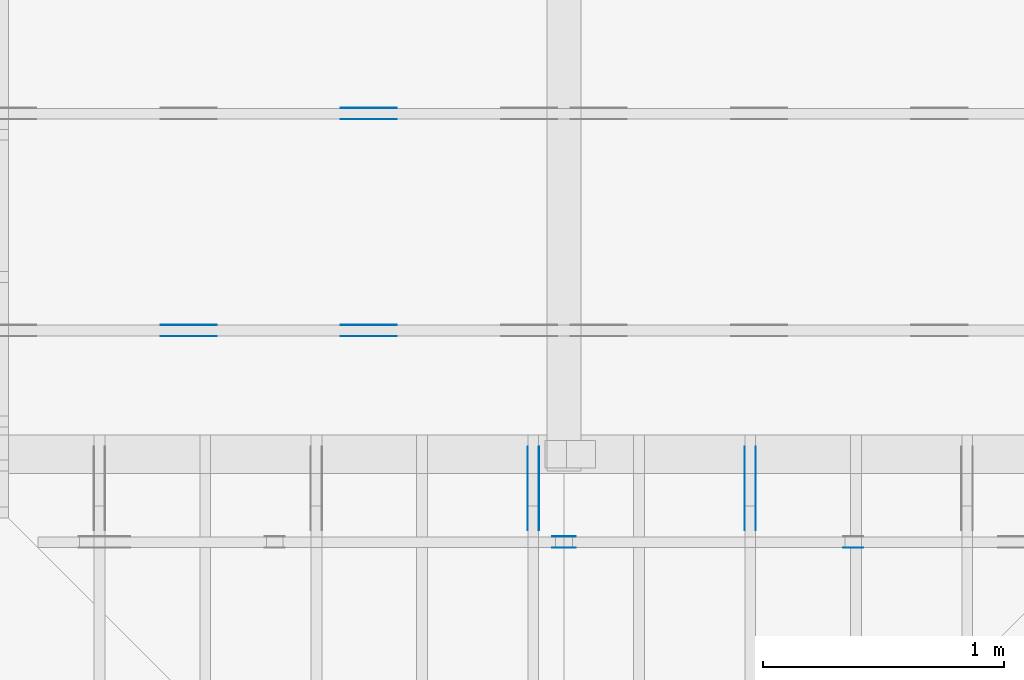
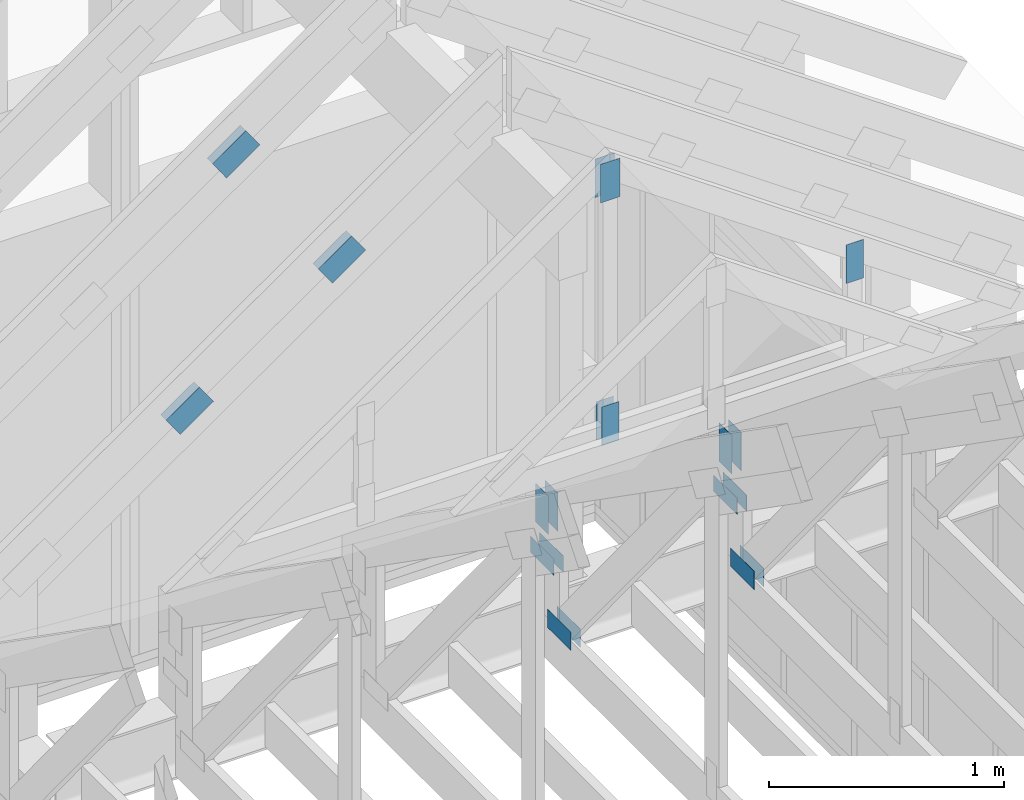
# One storey, part 62 of 70: 23 plates, 5 elements without a shape of their own.
"""IFC2X3 building model written with IfcOpenShell, lengths in millimetres."""

from ifc_helpers import new_model, si_unit, frame, origin, origin_with_axes, origin_2d, place, context, project, spatial, faceted_brep, element, aggregate, save


model = new_model("IFC2X3")

# Units and contexts
model_context = context("Model", 3, precision=1e-05, world=origin())
plan_context = context("Plan", 2, precision=1e-05, world=origin_2d())
ifc_project = project(units=[si_unit("LENGTHUNIT", "METRE", prefix="MILLI"), si_unit("AREAUNIT", "SQUARE_METRE"), si_unit("VOLUMEUNIT", "CUBIC_METRE"), si_unit("SOLIDANGLEUNIT", "STERADIAN"), si_unit("PLANEANGLEUNIT", "RADIAN"), si_unit("MASSUNIT", "GRAM"), si_unit("TIMEUNIT", "SECOND"), si_unit("THERMODYNAMICTEMPERATUREUNIT", "DEGREE_CELSIUS"), si_unit("LUMINOUSINTENSITYUNIT", "LUMEN")], contexts=[model_context, plan_context])

# Site, building, storey
site_placement = place(None, origin_with_axes())
site = spatial("IfcSite", under=ifc_project, at=site_placement, CompositionType="ELEMENT")
building_placement = place(site_placement, origin_with_axes())
building = spatial("IfcBuilding", under=site, at=building_placement, Name="Layout 1", CompositionType="ELEMENT")
storey_placement = place(building_placement, origin_with_axes())
storey = spatial("IfcBuildingStorey", under=building, at=storey_placement, Name="Storey 1", CompositionType="ELEMENT", Elevation=0.0)

# Assembly, plates
assembly_1_placement = place(storey_placement, frame((7000.0, 9505.0, 1.3776821480501744e-15), z_axis=(1.2246063538223773e-16, 1.0, 6.123031769111886e-17), x_axis=(-1.0, 1.2246063538223773e-16, 0.0)))
assembly_1 = element("IfcElementAssembly", 1, at=assembly_1_placement, inside=storey, Name="T4", AssemblyPlace="FACTORY", PredefinedType="TRUSS")
plate_1_placement = place(assembly_1_placement, frame((-1806.2295569137375, 1953.4380313546214, 0.0), z_axis=(0.0, 0.0, 1.0), x_axis=(0.819152044288992, -0.5735764363510462, 0.0)))
plate_1 = element("IfcPlate", 2, at=plate_1_placement, context=model_context, shape_type="Brep", body=[
    faceted_brep([(200.00000000000045, 120.00000000000023, 1.3), (0.0, 120.00000000000023, 1.3), (4.547473508864641e-13, 1.1368683772161603e-13, 1.3), (200.00000000000045, 1.1368683772161603e-13, 1.3), (0.0, 120.00000000000023, 0.0), (200.00000000000045, 120.00000000000023, 2.4492127076447602e-14), (200.00000000000045, 0.0, 2.4492127076447602e-14), (4.547473508864641e-13, 0.0, 5.56886495279458e-29), (200.00000000000045, -1.0068703683308056e-13, 6.165099252666911e-30), (200.00000000000045, -1.006074374200821e-13, 1.3), (4.547473508864641e-13, 1.1376643713461424e-13, 1.3), (4.547473508864641e-13, 1.1368683772161579e-13, 1.401298464324817e-44), (200.00000000000045, 120.0, 0.0), (200.00000000000045, 120.0, 1.3), (200.00000000000045, 0.0, 1.3), (200.00000000000045, 0.0, 0.0), (0.0, 120.00000000000023, 0.0), (0.0, 120.00000000000023, 1.3), (200.00000000000045, 120.0, 1.3), (200.00000000000045, 120.0, 0.0), (4.547473508864642e-13, 1.1368683772161603e-13, -1.1210387714598537e-44), (4.548269502994627e-13, 1.1368683772161603e-13, 1.3), (4.3196585089270716e-14, 120.00000000000023, 1.3), (4.311698567627228e-14, 120.00000000000023, -2.6400667308415748e-30)], [[[0, 1, 2, 3]], [[4, 5, 6, 7]], [[8, 9, 10, 11]], [[12, 13, 14, 15]], [[16, 17, 18, 19]], [[20, 21, 22, 23]]]),
])
plate_2_placement = place(assembly_1_placement, frame((-1806.2295569137375, 1953.4380313546214, -46.300000000000004), z_axis=(0.0, 0.0, 1.0), x_axis=(0.819152044288992, -0.5735764363510462, 0.0)))
plate_2 = element("IfcPlate", 3, at=plate_2_placement, context=model_context, shape_type="Brep", body=[
    faceted_brep([(200.00000000000045, 120.00000000000023, 1.2999999999999972), (0.0, 120.00000000000023, 1.2999999999999972), (4.547473508864641e-13, 1.1368683772161603e-13, 1.2999999999999972), (200.00000000000045, 1.1368683772161603e-13, 1.2999999999999972), (0.0, 120.00000000000023, 0.0), (200.00000000000045, 120.00000000000023, 2.4492127076447602e-14), (200.00000000000045, 0.0, 2.4492127076447602e-14), (4.547473508864641e-13, 0.0, 5.56886495279458e-29), (200.00000000000045, -1.0068703683308056e-13, 6.165099252666911e-30), (200.00000000000045, -1.006074374200821e-13, 1.2999999999999972), (4.547473508864641e-13, 1.1376643713461424e-13, 1.2999999999999972), (4.547473508864641e-13, 1.1368683772161579e-13, 1.401298464324817e-44), (200.00000000000045, 120.0, 0.0), (200.00000000000045, 120.0, 1.2999999999999972), (200.00000000000045, 0.0, 1.2999999999999972), (200.00000000000045, 0.0, 0.0), (0.0, 120.00000000000023, 0.0), (0.0, 120.00000000000023, 1.2999999999999972), (200.00000000000045, 120.0, 1.2999999999999972), (200.00000000000045, 120.0, 0.0), (4.547473508864642e-13, 1.1368683772161603e-13, -1.1210387714598537e-44), (4.548269502994627e-13, 1.1368683772161603e-13, 1.2999999999999972), (4.3196585089270716e-14, 120.00000000000023, 1.2999999999999972), (4.311698567627228e-14, 120.00000000000023, -2.6400667308415748e-30)], [[[0, 1, 2, 3]], [[4, 5, 6, 7]], [[8, 9, 10, 11]], [[12, 13, 14, 15]], [[16, 17, 18, 19]], [[20, 21, 22, 23]]]),
])
aggregate(assembly_1, [plate_1, plate_2])

assembly_2_placement = place(storey_placement, frame((7000.0, 8605.0, 1.3776821480501744e-15), z_axis=(1.2246063538223773e-16, 1.0, 6.123031769111886e-17), x_axis=(-1.0, 1.2246063538223773e-16, 0.0)))
assembly_2 = element("IfcElementAssembly", 4, at=assembly_2_placement, inside=storey, Name="T4", AssemblyPlace="FACTORY", PredefinedType="TRUSS")
plate_3_placement = place(assembly_2_placement, frame((-1058.7796737620245, 1430.0679887373412, 0.0), z_axis=(0.0, 0.0, 1.0), x_axis=(0.819152044288992, -0.5735764363510462, 0.0)))
plate_3 = element("IfcPlate", 5, at=plate_3_placement, context=model_context, shape_type="Brep", body=[
    faceted_brep([(200.00000000000023, 120.0, 1.3), (0.0, 120.0, 1.3), (2.2737367544323206e-13, 0.0, 1.3), (200.0, 0.0, 1.3), (0.0, 120.0, 0.0), (200.00000000000023, 120.0, 2.4492127076447574e-14), (200.0, 0.0, 2.4492127076447545e-14), (2.2737367544323206e-13, 0.0, 2.78443247639729e-29), (200.0, -3.673819061467132e-14, 2.249491082733206e-30), (200.0, -3.6658591201672864e-14, 1.3), (2.2737367544323206e-13, 7.959941299841276e-17, 1.3), (2.2737367544323206e-13, -4.176648714595935e-29, 2.5573752767891235e-45), (200.0, 120.0, -1.4199496293978212e-29), (200.0, 120.0, 1.3), (200.0, 0.0, 1.3), (200.0, 0.0, 0.0), (0.0, 120.0, 0.0), (-4.8738973459219465e-33, 120.0, 1.3), (200.00000000000023, 119.99999999999999, 1.3), (200.00000000000023, 119.99999999999999, 0.0), (2.2737367544323206e-13, 0.0, 0.0), (2.274532748562305e-13, 1.669984074232364e-31, 1.3), (-2.430497480793855e-14, 120.0, 1.3), (-2.4384574220936983e-14, 120.0, 1.4930752263106387e-30)], [[[0, 1, 2, 3]], [[4, 5, 6, 7]], [[8, 9, 10, 11]], [[12, 13, 14, 15]], [[16, 17, 18, 19]], [[20, 21, 22, 23]]]),
])
plate_4_placement = place(assembly_2_placement, frame((-1058.7796737620245, 1430.0679887373412, -46.300000000000004), z_axis=(0.0, 0.0, 1.0), x_axis=(0.819152044288992, -0.5735764363510462, 0.0)))
plate_4 = element("IfcPlate", 6, at=plate_4_placement, context=model_context, shape_type="Brep", body=[
    faceted_brep([(200.00000000000023, 120.0, 1.2999999999999972), (0.0, 120.0, 1.2999999999999972), (2.2737367544323206e-13, 0.0, 1.2999999999999972), (200.0, 0.0, 1.2999999999999972), (0.0, 120.0, 0.0), (200.00000000000023, 120.0, 2.4492127076447574e-14), (200.0, 0.0, 2.4492127076447545e-14), (2.2737367544323206e-13, 0.0, 2.78443247639729e-29), (200.0, -3.673819061467132e-14, 2.249491082733206e-30), (200.0, -3.6658591201672864e-14, 1.2999999999999972), (2.2737367544323206e-13, 7.959941299841258e-17, 1.2999999999999972), (2.2737367544323206e-13, -4.176648714595935e-29, 2.5573752767891235e-45), (200.0, 120.0, -1.4199496293978212e-29), (200.0, 120.0, 1.2999999999999972), (200.0, 0.0, 1.2999999999999972), (200.0, 0.0, 0.0), (0.0, 120.0, 0.0), (-4.873897345921936e-33, 120.0, 1.2999999999999972), (200.00000000000023, 119.99999999999999, 1.2999999999999972), (200.00000000000023, 119.99999999999999, 0.0), (2.2737367544323206e-13, 0.0, 0.0), (2.274532748562305e-13, 1.669984074232364e-31, 1.2999999999999972), (-2.430497480793855e-14, 120.0, 1.2999999999999972), (-2.4384574220936983e-14, 120.0, 1.4930752263106387e-30)], [[[0, 1, 2, 3]], [[4, 5, 6, 7]], [[8, 9, 10, 11]], [[12, 13, 14, 15]], [[16, 17, 18, 19]], [[20, 21, 22, 23]]]),
])
plate_5_placement = place(assembly_2_placement, frame((-1806.2295569137375, 1953.4380313546214, 0.0), z_axis=(0.0, 0.0, 1.0), x_axis=(0.819152044288992, -0.5735764363510462, 0.0)))
plate_5 = element("IfcPlate", 7, at=plate_5_placement, context=model_context, shape_type="Brep", body=[
    faceted_brep([(200.00000000000045, 120.00000000000023, 1.3), (0.0, 120.00000000000023, 1.3), (4.547473508864641e-13, 1.1368683772161603e-13, 1.3), (200.00000000000045, 1.1368683772161603e-13, 1.3), (0.0, 120.00000000000023, 0.0), (200.00000000000045, 120.00000000000023, 2.4492127076447602e-14), (200.00000000000045, 0.0, 2.4492127076447602e-14), (4.547473508864641e-13, 0.0, 5.56886495279458e-29), (200.00000000000045, -1.0068703683308056e-13, 6.165099252666911e-30), (200.00000000000045, -1.006074374200821e-13, 1.3), (4.547473508864641e-13, 1.1376643713461424e-13, 1.3), (4.547473508864641e-13, 1.1368683772161579e-13, 1.401298464324817e-44), (200.00000000000045, 120.0, 0.0), (200.00000000000045, 120.0, 1.3), (200.00000000000045, 0.0, 1.3), (200.00000000000045, 0.0, 0.0), (0.0, 120.00000000000023, 0.0), (0.0, 120.00000000000023, 1.3), (200.00000000000045, 120.0, 1.3), (200.00000000000045, 120.0, 0.0), (4.547473508864642e-13, 1.1368683772161603e-13, -1.1210387714598537e-44), (4.548269502994627e-13, 1.1368683772161603e-13, 1.3), (4.3196585089270716e-14, 120.00000000000023, 1.3), (4.311698567627228e-14, 120.00000000000023, -2.6400667308415748e-30)], [[[0, 1, 2, 3]], [[4, 5, 6, 7]], [[8, 9, 10, 11]], [[12, 13, 14, 15]], [[16, 17, 18, 19]], [[20, 21, 22, 23]]]),
])
plate_6_placement = place(assembly_2_placement, frame((-1806.2295569137375, 1953.4380313546214, -46.300000000000004), z_axis=(0.0, 0.0, 1.0), x_axis=(0.819152044288992, -0.5735764363510462, 0.0)))
plate_6 = element("IfcPlate", 8, at=plate_6_placement, context=model_context, shape_type="Brep", body=[
    faceted_brep([(200.00000000000045, 120.00000000000023, 1.2999999999999972), (0.0, 120.00000000000023, 1.2999999999999972), (4.547473508864641e-13, 1.1368683772161603e-13, 1.2999999999999972), (200.00000000000045, 1.1368683772161603e-13, 1.2999999999999972), (0.0, 120.00000000000023, 0.0), (200.00000000000045, 120.00000000000023, 2.4492127076447602e-14), (200.00000000000045, 0.0, 2.4492127076447602e-14), (4.547473508864641e-13, 0.0, 5.56886495279458e-29), (200.00000000000045, -1.0068703683308056e-13, 6.165099252666911e-30), (200.00000000000045, -1.006074374200821e-13, 1.2999999999999972), (4.547473508864641e-13, 1.1376643713461424e-13, 1.2999999999999972), (4.547473508864641e-13, 1.1368683772161579e-13, 1.401298464324817e-44), (200.00000000000045, 120.0, 0.0), (200.00000000000045, 120.0, 1.2999999999999972), (200.00000000000045, 0.0, 1.2999999999999972), (200.00000000000045, 0.0, 0.0), (0.0, 120.00000000000023, 0.0), (0.0, 120.00000000000023, 1.2999999999999972), (200.00000000000045, 120.0, 1.2999999999999972), (200.00000000000045, 120.0, 0.0), (4.547473508864642e-13, 1.1368683772161603e-13, -1.1210387714598537e-44), (4.548269502994627e-13, 1.1368683772161603e-13, 1.2999999999999972), (4.3196585089270716e-14, 120.00000000000023, 1.2999999999999972), (4.311698567627228e-14, 120.00000000000023, -2.6400667308415748e-30)], [[[0, 1, 2, 3]], [[4, 5, 6, 7]], [[8, 9, 10, 11]], [[12, 13, 14, 15]], [[16, 17, 18, 19]], [[20, 21, 22, 23]]]),
])
aggregate(assembly_2, [plate_3, plate_4, plate_5, plate_6])

assembly_3_placement = place(storey_placement, frame((10250.0, 8000.0, -9.081170196248781e-13), z_axis=(-1.0, 1.836909530733566e-16, 6.123031769111886e-17), x_axis=(-1.836909530733566e-16, -1.0, 0.0)))
assembly_3 = element("IfcElementAssembly", 9, at=assembly_3_placement, inside=storey, Name="T3", AssemblyPlace="FACTORY", PredefinedType="TRUSS")
plate_7_placement = place(assembly_3_placement, frame((100.0, 559.2244775947038, 0.0), z_axis=(0.0, 0.0, 1.0), x_axis=(-1.0, 1.2246063538223773e-16, 0.0)))
plate_7 = element("IfcPlate", 10, at=plate_7_placement, context=model_context, shape_type="Brep", body=[
    faceted_brep([(200.0, 84.0, 1.3), (0.0, 84.0, 1.3), (0.0, 0.0, 1.3), (200.0, 0.0, 1.3), (0.0, 84.0, 0.0), (200.0, 84.0, 2.4492127076447545e-14), (200.0, 0.0, 2.4492127076447545e-14), (0.0, 0.0, 0.0), (200.0, -3.673819061467132e-14, 2.249491082733206e-30), (200.0, -3.6658591201672864e-14, 1.3), (1.4621692037765842e-32, 7.959941299845453e-17, 1.3), (0.0, 0.0, 0.0), (200.0, 84.0, 0.0), (200.0, 84.0, 1.3), (200.0, 0.0, 1.3), (200.0, 0.0, 0.0), (0.0, 84.0, 0.0), (-4.8738973459219465e-33, 84.0, 1.3), (200.0, 83.99999999999999, 1.3), (200.0, 83.99999999999999, -7.888609052210118e-31), (0.0, 0.0, 0.0), (7.959941299845453e-17, -9.747794691843893e-33, 1.3), (1.0366292785106424e-14, 84.0, 1.3), (1.0286693372107969e-14, 84.0, -6.298575031652977e-31)], [[[0, 1, 2, 3]], [[4, 5, 6, 7]], [[8, 9, 10, 11]], [[12, 13, 14, 15]], [[16, 17, 18, 19]], [[20, 21, 22, 23]]]),
])
plate_8_placement = place(assembly_3_placement, frame((100.0, 559.2244775947038, -46.3), z_axis=(0.0, 0.0, 1.0), x_axis=(-1.0, 1.2246063538223773e-16, 0.0)))
plate_8 = element("IfcPlate", 11, at=plate_8_placement, context=model_context, shape_type="Brep", body=[
    faceted_brep([(200.0, 84.0, 1.2999999999999972), (0.0, 84.0, 1.2999999999999972), (0.0, 0.0, 1.2999999999999972), (200.0, 0.0, 1.2999999999999972), (0.0, 84.0, 0.0), (200.0, 84.0, 2.4492127076447545e-14), (200.0, 0.0, 2.4492127076447545e-14), (0.0, 0.0, 0.0), (200.0, -3.673819061467132e-14, 2.249491082733206e-30), (200.0, -3.6658591201672864e-14, 1.2999999999999972), (1.462169203776581e-32, 7.959941299845434e-17, 1.2999999999999972), (0.0, 0.0, 0.0), (200.0, 84.0, 0.0), (200.0, 84.0, 1.2999999999999972), (200.0, 0.0, 1.2999999999999972), (200.0, 0.0, 0.0), (0.0, 84.0, 0.0), (-4.873897345921936e-33, 84.0, 1.2999999999999972), (200.0, 83.99999999999999, 1.2999999999999972), (200.0, 83.99999999999999, -7.888609052210118e-31), (0.0, 0.0, 0.0), (7.959941299845434e-17, -9.747794691843873e-33, 1.2999999999999972), (1.0366292785106424e-14, 84.0, 1.2999999999999972), (1.0286693372107969e-14, 84.0, -6.298575031652977e-31)], [[[0, 1, 2, 3]], [[4, 5, 6, 7]], [[8, 9, 10, 11]], [[12, 13, 14, 15]], [[16, 17, 18, 19]], [[20, 21, 22, 23]]]),
])
plate_9_placement = place(assembly_3_placement, frame((54.00000000004449, 658.8550844100489, 0.0), z_axis=(0.0, 0.0, 1.0), x_axis=(6.123031769111886e-17, 1.0, 0.0)))
plate_9 = element("IfcPlate", 12, at=plate_9_placement, context=model_context, shape_type="Brep", body=[
    faceted_brep([(200.0, 108.0, 1.3), (0.0, 108.0, 1.3), (0.0, 7.105427357601002e-15, 1.3), (200.0, 7.105427357601002e-15, 1.3), (0.0, 108.0, 0.0), (200.0, 108.0, 2.4492127076447545e-14), (200.0, 0.0, 2.4492127076447545e-14), (0.0, 0.0, 0.0), (200.0, -2.9632763257070316e-14, 1.8144235082961296e-30), (200.0, -2.955316384407186e-14, 1.3), (1.4621692037765823e-32, 7.185026770599457e-15, 1.3), (0.0, 7.105427357601002e-15, 0.0), (200.0, 108.0, 0.0), (200.0, 108.0, 1.3), (200.0, 0.0, 1.3), (200.0, 0.0, 0.0), (0.0, 108.0, 0.0), (-4.8738973459219465e-33, 108.0, 1.3), (200.0, 107.99999999999999, 1.3), (200.0, 107.99999999999999, -7.888609052210118e-31), (8.701351488741532e-31, 7.105427357601002e-15, -5.327865159977341e-47), (7.95994129984554e-17, 7.105427357601002e-15, 1.3), (1.330534803428013e-14, 108.0, 1.3), (1.3225748621281674e-14, 108.0, -8.098167897839542e-31)], [[[0, 1, 2, 3]], [[4, 5, 6, 7]], [[8, 9, 10, 11]], [[12, 13, 14, 15]], [[16, 17, 18, 19]], [[20, 21, 22, 23]]]),
])
plate_10_placement = place(assembly_3_placement, frame((54.00000000004449, 658.8550844100489, -46.3), z_axis=(0.0, 0.0, 1.0), x_axis=(6.123031769111886e-17, 1.0, 0.0)))
plate_10 = element("IfcPlate", 13, at=plate_10_placement, context=model_context, shape_type="Brep", body=[
    faceted_brep([(200.0, 108.0, 1.2999999999999972), (0.0, 108.0, 1.2999999999999972), (0.0, 7.105427357601002e-15, 1.2999999999999972), (200.0, 7.105427357601002e-15, 1.2999999999999972), (0.0, 108.0, 0.0), (200.0, 108.0, 2.4492127076447545e-14), (200.0, 0.0, 2.4492127076447545e-14), (0.0, 0.0, 0.0), (200.0, -2.9632763257070316e-14, 1.8144235082961296e-30), (200.0, -2.955316384407186e-14, 1.2999999999999972), (1.4621692037765823e-32, 7.185026770599457e-15, 1.2999999999999972), (0.0, 7.105427357601002e-15, 0.0), (200.0, 108.0, 0.0), (200.0, 108.0, 1.2999999999999972), (200.0, 0.0, 1.2999999999999972), (200.0, 0.0, 0.0), (0.0, 108.0, 0.0), (-4.873897345921936e-33, 108.0, 1.2999999999999972), (200.0, 107.99999999999999, 1.2999999999999972), (200.0, 107.99999999999999, -7.888609052210118e-31), (8.701351488741532e-31, 7.105427357601002e-15, -5.327865159977341e-47), (7.959941299845522e-17, 7.105427357601002e-15, 1.2999999999999972), (1.330534803428013e-14, 108.0, 1.2999999999999972), (1.3225748621281674e-14, 108.0, -8.098167897839542e-31)], [[[0, 1, 2, 3]], [[4, 5, 6, 7]], [[8, 9, 10, 11]], [[12, 13, 14, 15]], [[16, 17, 18, 19]], [[20, 21, 22, 23]]]),
])
plate_11_placement = place(assembly_3_placement, frame((44.999999998137355, 172.00000000000097, 0.0), z_axis=(0.0, 0.0, 1.0), x_axis=(1.0, 0.0, 0.0)))
plate_11 = element("IfcPlate", 14, at=plate_11_placement, context=model_context, shape_type="Brep", body=[
    faceted_brep([(200.0, 96.0, 1.3), (0.0, 96.0, 1.3), (0.0, 0.0, 1.3), (200.0, 0.0, 1.3), (0.0, 96.0, 0.0), (200.0, 96.0, 2.4492127076447545e-14), (200.0, 0.0, 2.4492127076447545e-14), (0.0, 0.0, 0.0), (200.0, -3.673819061467132e-14, 2.249491082733206e-30), (200.0, -3.6658591201672864e-14, 1.3), (1.4621692037765842e-32, 7.959941299845453e-17, 1.3), (0.0, 0.0, 0.0), (200.0, 96.0, 0.0), (200.0, 96.0, 1.3), (200.0, 0.0, 1.3), (200.0, 0.0, 0.0), (0.0, 96.0, 0.0), (-4.8738973459219465e-33, 96.0, 1.3), (200.0, 95.99999999999999, 1.3), (200.0, 95.99999999999999, -7.888609052210118e-31), (0.0, 0.0, 0.0), (7.959941299845453e-17, -9.747794691843893e-33, 1.3), (1.1835820409693277e-14, 96.0, 1.3), (1.1756220996694822e-14, 96.0, -7.19837146474626e-31)], [[[0, 1, 2, 3]], [[4, 5, 6, 7]], [[8, 9, 10, 11]], [[12, 13, 14, 15]], [[16, 17, 18, 19]], [[20, 21, 22, 23]]]),
])
plate_12_placement = place(assembly_3_placement, frame((44.999999998137355, 172.00000000000097, -46.3), z_axis=(0.0, 0.0, 1.0), x_axis=(1.0, 0.0, 0.0)))
plate_12 = element("IfcPlate", 15, at=plate_12_placement, context=model_context, shape_type="Brep", body=[
    faceted_brep([(200.0, 96.0, 1.2999999999999972), (0.0, 96.0, 1.2999999999999972), (0.0, 0.0, 1.2999999999999972), (200.0, 0.0, 1.2999999999999972), (0.0, 96.0, 0.0), (200.0, 96.0, 2.4492127076447545e-14), (200.0, 0.0, 2.4492127076447545e-14), (0.0, 0.0, 0.0), (200.0, -3.673819061467132e-14, 2.249491082733206e-30), (200.0, -3.6658591201672864e-14, 1.2999999999999972), (1.462169203776581e-32, 7.959941299845434e-17, 1.2999999999999972), (0.0, 0.0, 0.0), (200.0, 96.0, 0.0), (200.0, 96.0, 1.2999999999999972), (200.0, 0.0, 1.2999999999999972), (200.0, 0.0, 0.0), (0.0, 96.0, 0.0), (-4.873897345921936e-33, 96.0, 1.2999999999999972), (200.0, 95.99999999999999, 1.2999999999999972), (200.0, 95.99999999999999, -7.888609052210118e-31), (0.0, 0.0, 0.0), (7.959941299845434e-17, -9.747794691843873e-33, 1.2999999999999972), (1.1835820409693277e-14, 96.0, 1.2999999999999972), (1.1756220996694822e-14, 96.0, -7.19837146474626e-31)], [[[0, 1, 2, 3]], [[4, 5, 6, 7]], [[8, 9, 10, 11]], [[12, 13, 14, 15]], [[16, 17, 18, 19]], [[20, 21, 22, 23]]]),
])
aggregate(assembly_3, [plate_7, plate_8, plate_9, plate_10, plate_11, plate_12])

assembly_4_placement = place(storey_placement, frame((9350.0, 8000.0, -9.081170196248781e-13), z_axis=(-1.0, 1.836909530733566e-16, 6.123031769111886e-17), x_axis=(-1.836909530733566e-16, -1.0, 0.0)))
assembly_4 = element("IfcElementAssembly", 16, at=assembly_4_placement, inside=storey, Name="T3", AssemblyPlace="FACTORY", PredefinedType="TRUSS")
plate_13_placement = place(assembly_4_placement, frame((100.0, 559.2244775947038, 0.0), z_axis=(0.0, 0.0, 1.0), x_axis=(-1.0, 1.2246063538223773e-16, 0.0)))
plate_13 = element("IfcPlate", 17, at=plate_13_placement, context=model_context, shape_type="Brep", body=[
    faceted_brep([(200.0, 84.0, 1.3), (0.0, 84.0, 1.3), (0.0, 0.0, 1.3), (200.0, 0.0, 1.3), (0.0, 84.0, 0.0), (200.0, 84.0, 2.4492127076447545e-14), (200.0, 0.0, 2.4492127076447545e-14), (0.0, 0.0, 0.0), (200.0, -3.673819061467132e-14, 2.249491082733206e-30), (200.0, -3.6658591201672864e-14, 1.3), (1.4621692037765842e-32, 7.959941299845453e-17, 1.3), (0.0, 0.0, 0.0), (200.0, 84.0, 0.0), (200.0, 84.0, 1.3), (200.0, 0.0, 1.3), (200.0, 0.0, 0.0), (0.0, 84.0, 0.0), (-4.8738973459219465e-33, 84.0, 1.3), (200.0, 83.99999999999999, 1.3), (200.0, 83.99999999999999, -7.888609052210118e-31), (0.0, 0.0, 0.0), (7.959941299845453e-17, -9.747794691843893e-33, 1.3), (1.0366292785106424e-14, 84.0, 1.3), (1.0286693372107969e-14, 84.0, -6.298575031652977e-31)], [[[0, 1, 2, 3]], [[4, 5, 6, 7]], [[8, 9, 10, 11]], [[12, 13, 14, 15]], [[16, 17, 18, 19]], [[20, 21, 22, 23]]]),
])
plate_14_placement = place(assembly_4_placement, frame((100.0, 559.2244775947038, -46.3), z_axis=(0.0, 0.0, 1.0), x_axis=(-1.0, 1.2246063538223773e-16, 0.0)))
plate_14 = element("IfcPlate", 18, at=plate_14_placement, context=model_context, shape_type="Brep", body=[
    faceted_brep([(200.0, 84.0, 1.2999999999999972), (0.0, 84.0, 1.2999999999999972), (0.0, 0.0, 1.2999999999999972), (200.0, 0.0, 1.2999999999999972), (0.0, 84.0, 0.0), (200.0, 84.0, 2.4492127076447545e-14), (200.0, 0.0, 2.4492127076447545e-14), (0.0, 0.0, 0.0), (200.0, -3.673819061467132e-14, 2.249491082733206e-30), (200.0, -3.6658591201672864e-14, 1.2999999999999972), (1.462169203776581e-32, 7.959941299845434e-17, 1.2999999999999972), (0.0, 0.0, 0.0), (200.0, 84.0, 0.0), (200.0, 84.0, 1.2999999999999972), (200.0, 0.0, 1.2999999999999972), (200.0, 0.0, 0.0), (0.0, 84.0, 0.0), (-4.873897345921936e-33, 84.0, 1.2999999999999972), (200.0, 83.99999999999999, 1.2999999999999972), (200.0, 83.99999999999999, -7.888609052210118e-31), (0.0, 0.0, 0.0), (7.959941299845434e-17, -9.747794691843873e-33, 1.2999999999999972), (1.0366292785106424e-14, 84.0, 1.2999999999999972), (1.0286693372107969e-14, 84.0, -6.298575031652977e-31)], [[[0, 1, 2, 3]], [[4, 5, 6, 7]], [[8, 9, 10, 11]], [[12, 13, 14, 15]], [[16, 17, 18, 19]], [[20, 21, 22, 23]]]),
])
plate_15_placement = place(assembly_4_placement, frame((54.00000000004449, 658.8550844100489, 0.0), z_axis=(0.0, 0.0, 1.0), x_axis=(6.123031769111886e-17, 1.0, 0.0)))
plate_15 = element("IfcPlate", 19, at=plate_15_placement, context=model_context, shape_type="Brep", body=[
    faceted_brep([(200.0, 108.0, 1.3), (0.0, 108.0, 1.3), (0.0, 7.105427357601002e-15, 1.3), (200.0, 7.105427357601002e-15, 1.3), (0.0, 108.0, 0.0), (200.0, 108.0, 2.4492127076447545e-14), (200.0, 0.0, 2.4492127076447545e-14), (0.0, 0.0, 0.0), (200.0, -2.9632763257070316e-14, 1.8144235082961296e-30), (200.0, -2.955316384407186e-14, 1.3), (1.4621692037765823e-32, 7.185026770599457e-15, 1.3), (0.0, 7.105427357601002e-15, 0.0), (200.0, 108.0, 0.0), (200.0, 108.0, 1.3), (200.0, 0.0, 1.3), (200.0, 0.0, 0.0), (0.0, 108.0, 0.0), (-4.8738973459219465e-33, 108.0, 1.3), (200.0, 107.99999999999999, 1.3), (200.0, 107.99999999999999, -7.888609052210118e-31), (8.701351488741532e-31, 7.105427357601002e-15, -5.327865159977341e-47), (7.95994129984554e-17, 7.105427357601002e-15, 1.3), (1.330534803428013e-14, 108.0, 1.3), (1.3225748621281674e-14, 108.0, -8.098167897839542e-31)], [[[0, 1, 2, 3]], [[4, 5, 6, 7]], [[8, 9, 10, 11]], [[12, 13, 14, 15]], [[16, 17, 18, 19]], [[20, 21, 22, 23]]]),
])
plate_16_placement = place(assembly_4_placement, frame((54.00000000004449, 658.8550844100489, -46.3), z_axis=(0.0, 0.0, 1.0), x_axis=(6.123031769111886e-17, 1.0, 0.0)))
plate_16 = element("IfcPlate", 20, at=plate_16_placement, context=model_context, shape_type="Brep", body=[
    faceted_brep([(200.0, 108.0, 1.2999999999999972), (0.0, 108.0, 1.2999999999999972), (0.0, 7.105427357601002e-15, 1.2999999999999972), (200.0, 7.105427357601002e-15, 1.2999999999999972), (0.0, 108.0, 0.0), (200.0, 108.0, 2.4492127076447545e-14), (200.0, 0.0, 2.4492127076447545e-14), (0.0, 0.0, 0.0), (200.0, -2.9632763257070316e-14, 1.8144235082961296e-30), (200.0, -2.955316384407186e-14, 1.2999999999999972), (1.4621692037765823e-32, 7.185026770599457e-15, 1.2999999999999972), (0.0, 7.105427357601002e-15, 0.0), (200.0, 108.0, 0.0), (200.0, 108.0, 1.2999999999999972), (200.0, 0.0, 1.2999999999999972), (200.0, 0.0, 0.0), (0.0, 108.0, 0.0), (-4.873897345921936e-33, 108.0, 1.2999999999999972), (200.0, 107.99999999999999, 1.2999999999999972), (200.0, 107.99999999999999, -7.888609052210118e-31), (8.701351488741532e-31, 7.105427357601002e-15, -5.327865159977341e-47), (7.959941299845522e-17, 7.105427357601002e-15, 1.2999999999999972), (1.330534803428013e-14, 108.0, 1.2999999999999972), (1.3225748621281674e-14, 108.0, -8.098167897839542e-31)], [[[0, 1, 2, 3]], [[4, 5, 6, 7]], [[8, 9, 10, 11]], [[12, 13, 14, 15]], [[16, 17, 18, 19]], [[20, 21, 22, 23]]]),
])
plate_17_placement = place(assembly_4_placement, frame((44.999999998137355, 172.00000000000097, 0.0), z_axis=(0.0, 0.0, 1.0), x_axis=(1.0, 0.0, 0.0)))
plate_17 = element("IfcPlate", 21, at=plate_17_placement, context=model_context, shape_type="Brep", body=[
    faceted_brep([(200.0, 96.0, 1.3), (0.0, 96.0, 1.3), (0.0, 0.0, 1.3), (200.0, 0.0, 1.3), (0.0, 96.0, 0.0), (200.0, 96.0, 2.4492127076447545e-14), (200.0, 0.0, 2.4492127076447545e-14), (0.0, 0.0, 0.0), (200.0, -3.673819061467132e-14, 2.249491082733206e-30), (200.0, -3.6658591201672864e-14, 1.3), (1.4621692037765842e-32, 7.959941299845453e-17, 1.3), (0.0, 0.0, 0.0), (200.0, 96.0, 0.0), (200.0, 96.0, 1.3), (200.0, 0.0, 1.3), (200.0, 0.0, 0.0), (0.0, 96.0, 0.0), (-4.8738973459219465e-33, 96.0, 1.3), (200.0, 95.99999999999999, 1.3), (200.0, 95.99999999999999, -7.888609052210118e-31), (0.0, 0.0, 0.0), (7.959941299845453e-17, -9.747794691843893e-33, 1.3), (1.1835820409693277e-14, 96.0, 1.3), (1.1756220996694822e-14, 96.0, -7.19837146474626e-31)], [[[0, 1, 2, 3]], [[4, 5, 6, 7]], [[8, 9, 10, 11]], [[12, 13, 14, 15]], [[16, 17, 18, 19]], [[20, 21, 22, 23]]]),
])
plate_18_placement = place(assembly_4_placement, frame((44.999999998137355, 172.00000000000097, -46.3), z_axis=(0.0, 0.0, 1.0), x_axis=(1.0, 0.0, 0.0)))
plate_18 = element("IfcPlate", 22, at=plate_18_placement, context=model_context, shape_type="Brep", body=[
    faceted_brep([(200.0, 96.0, 1.2999999999999972), (0.0, 96.0, 1.2999999999999972), (0.0, 0.0, 1.2999999999999972), (200.0, 0.0, 1.2999999999999972), (0.0, 96.0, 0.0), (200.0, 96.0, 2.4492127076447545e-14), (200.0, 0.0, 2.4492127076447545e-14), (0.0, 0.0, 0.0), (200.0, -3.673819061467132e-14, 2.249491082733206e-30), (200.0, -3.6658591201672864e-14, 1.2999999999999972), (1.462169203776581e-32, 7.959941299845434e-17, 1.2999999999999972), (0.0, 0.0, 0.0), (200.0, 96.0, 0.0), (200.0, 96.0, 1.2999999999999972), (200.0, 0.0, 1.2999999999999972), (200.0, 0.0, 0.0), (0.0, 96.0, 0.0), (-4.873897345921936e-33, 96.0, 1.2999999999999972), (200.0, 95.99999999999999, 1.2999999999999972), (200.0, 95.99999999999999, -7.888609052210118e-31), (0.0, 0.0, 0.0), (7.959941299845434e-17, -9.747794691843873e-33, 1.2999999999999972), (1.1835820409693277e-14, 96.0, 1.2999999999999972), (1.1756220996694822e-14, 96.0, -7.19837146474626e-31)], [[[0, 1, 2, 3]], [[4, 5, 6, 7]], [[8, 9, 10, 11]], [[12, 13, 14, 15]], [[16, 17, 18, 19]], [[20, 21, 22, 23]]]),
])
aggregate(assembly_4, [plate_13, plate_14, plate_15, plate_16, plate_17, plate_18])

assembly_5_placement = place(storey_placement, frame((7294.999999999998, 7682.5, 1206.561223771864), z_axis=(0.0, -1.0, 6.123031769111886e-17), x_axis=(1.0, 0.0, 0.0)))
assembly_5 = element("IfcElementAssembly", 23, at=assembly_5_placement, inside=storey, Name="SB1", AssemblyPlace="FACTORY", PredefinedType="TRUSS")
plate_19_placement = place(assembly_5_placement, frame((2157.0, 1497.4646711014211, 0.0), z_axis=(0.0, 0.0, 1.0), x_axis=(6.123031769111886e-17, -1.0, 0.0)))
plate_19 = element("IfcPlate", 24, at=plate_19_placement, context=model_context, shape_type="Brep", body=[
    faceted_brep([(200.0, 96.0, 1.3), (0.0, 96.0, 1.3), (0.0, 0.0, 1.3), (200.0, 0.0, 1.3), (0.0, 96.0, 0.0), (200.0, 96.0, 2.4492127076447545e-14), (200.0, 0.0, 2.4492127076447545e-14), (0.0, 0.0, 0.0), (200.0, -3.673819061467132e-14, 2.249491082733206e-30), (200.0, -3.6658591201672864e-14, 1.3), (1.4621692037765842e-32, 7.959941299845453e-17, 1.3), (0.0, 0.0, 0.0), (200.0, 96.0, 0.0), (200.0, 96.0, 1.3), (200.0, 0.0, 1.3), (200.0, 0.0, 0.0), (0.0, 96.0, 0.0), (-4.8738973459219465e-33, 96.0, 1.3), (200.0, 95.99999999999999, 1.3), (200.0, 95.99999999999999, -7.888609052210118e-31), (0.0, 0.0, 0.0), (7.959941299845453e-17, -9.747794691843893e-33, 1.3), (1.1835820409693277e-14, 96.0, 1.3), (1.1756220996694822e-14, 96.0, -7.19837146474626e-31)], [[[0, 1, 2, 3]], [[4, 5, 6, 7]], [[8, 9, 10, 11]], [[12, 13, 14, 15]], [[16, 17, 18, 19]], [[20, 21, 22, 23]]]),
])
plate_20_placement = place(assembly_5_placement, frame((2157.0, 1497.4646711014211, -46.3), z_axis=(0.0, 0.0, 1.0), x_axis=(6.123031769111886e-17, -1.0, 0.0)))
plate_20 = element("IfcPlate", 25, at=plate_20_placement, context=model_context, shape_type="Brep", body=[
    faceted_brep([(200.0, 96.0, 1.2999999999999972), (0.0, 96.0, 1.2999999999999972), (0.0, 0.0, 1.2999999999999972), (200.0, 0.0, 1.2999999999999972), (0.0, 96.0, 0.0), (200.0, 96.0, 2.4492127076447545e-14), (200.0, 0.0, 2.4492127076447545e-14), (0.0, 0.0, 0.0), (200.0, -3.673819061467132e-14, 2.249491082733206e-30), (200.0, -3.6658591201672864e-14, 1.2999999999999972), (1.462169203776581e-32, 7.959941299845434e-17, 1.2999999999999972), (0.0, 0.0, 0.0), (200.0, 96.0, 0.0), (200.0, 96.0, 1.2999999999999972), (200.0, 0.0, 1.2999999999999972), (200.0, 0.0, 0.0), (0.0, 96.0, 0.0), (-4.873897345921936e-33, 96.0, 1.2999999999999972), (200.0, 95.99999999999999, 1.2999999999999972), (200.0, 95.99999999999999, -7.888609052210118e-31), (0.0, 0.0, 0.0), (7.959941299845434e-17, -9.747794691843873e-33, 1.2999999999999972), (1.1835820409693277e-14, 96.0, 1.2999999999999972), (1.1756220996694822e-14, 96.0, -7.19837146474626e-31)], [[[0, 1, 2, 3]], [[4, 5, 6, 7]], [[8, 9, 10, 11]], [[12, 13, 14, 15]], [[16, 17, 18, 19]], [[20, 21, 22, 23]]]),
])
plate_21_placement = place(assembly_5_placement, frame((3362.999999999998, 657.2156252501233, 0.0), z_axis=(0.0, 0.0, 1.0), x_axis=(-1.0489927069340377e-15, -1.0, 0.0)))
plate_21 = element("IfcPlate", 26, at=plate_21_placement, context=model_context, shape_type="Brep", body=[
    faceted_brep([(200.0, 84.0, 1.3), (0.0, 84.0, 1.3), (0.0, 0.0, 1.3), (200.0, 0.0, 1.3), (0.0, 84.0, 0.0), (200.0, 84.0, 2.4492127076447545e-14), (200.0, 4.547473508864641e-13, 2.4492127076447545e-14), (0.0, 4.547473508864641e-13, 0.0), (200.0, 3.185331772653788e-13, 8.340437124852278e-30), (200.0, 3.186127766783772e-13, 1.3), (-1.2677526965428406e-31, 7.959941299845453e-17, 1.3), (0.0, 0.0, 0.0), (200.0, 84.00000000000045, 0.0), (200.0, 84.00000000000045, 1.3), (200.0, 4.547473508864641e-13, 1.3), (200.0, 4.547473508864641e-13, 0.0), (0.0, 84.0, 0.0), (0.0, 84.0, 1.3), (200.0, 84.00000000000048, 1.3), (200.0, 84.00000000000048, 1.5777218104420236e-30), (0.0, 0.0, 0.0), (7.959941299845453e-17, -9.747794691843893e-33, 1.3), (1.0366292785106424e-14, 84.0, 1.3), (1.0286693372107969e-14, 84.0, -6.298575031652977e-31)], [[[0, 1, 2, 3]], [[4, 5, 6, 7]], [[8, 9, 10, 11]], [[12, 13, 14, 15]], [[16, 17, 18, 19]], [[20, 21, 22, 23]]]),
])
plate_22_placement = place(assembly_5_placement, frame((2247.0, 35.754669609013945, 0.0), z_axis=(0.0, 0.0, 1.0), x_axis=(6.123031769111886e-17, 1.0, 0.0)))
plate_22 = element("IfcPlate", 27, at=plate_22_placement, context=model_context, shape_type="Brep", body=[
    faceted_brep([(200.0, 84.0, 1.3), (7.105427357601002e-15, 84.0, 1.3), (0.0, 0.0, 1.3), (200.0, 0.0, 1.3), (7.105427357601002e-15, 84.0, 8.701351488741532e-31), (200.0, 84.0, 2.4492127076447545e-14), (200.0, 0.0, 2.4492127076447545e-14), (0.0, 0.0, 0.0), (200.0, -3.673819061467132e-14, 2.249491082733206e-30), (200.0, -3.6658591201672864e-14, 1.3), (1.4621692037765842e-32, 7.959941299845453e-17, 1.3), (0.0, 0.0, 0.0), (200.0, 84.0, 0.0), (200.0, 84.0, 1.3), (200.0, 0.0, 1.3), (200.0, 0.0, 0.0), (7.105427357601002e-15, 84.0, 0.0), (7.105427357601002e-15, 84.0, 1.3), (200.0, 83.99999999999999, 1.3), (200.0, 83.99999999999999, -7.888609052210118e-31), (0.0, 0.0, 0.0), (7.959941299845453e-17, -9.747794691843893e-33, 1.3), (1.0366292785106424e-14, 84.0, 1.3), (1.0286693372107969e-14, 84.0, -1.9478992872822115e-31)], [[[0, 1, 2, 3]], [[4, 5, 6, 7]], [[8, 9, 10, 11]], [[12, 13, 14, 15]], [[16, 17, 18, 19]], [[20, 21, 22, 23]]]),
])
plate_23_placement = place(assembly_5_placement, frame((2247.0, 35.754669609013945, -46.3), z_axis=(0.0, 0.0, 1.0), x_axis=(6.123031769111886e-17, 1.0, 0.0)))
plate_23 = element("IfcPlate", 28, at=plate_23_placement, context=model_context, shape_type="Brep", body=[
    faceted_brep([(200.0, 84.0, 1.2999999999999972), (7.105427357601002e-15, 84.0, 1.2999999999999972), (0.0, 0.0, 1.2999999999999972), (200.0, 0.0, 1.2999999999999972), (7.105427357601002e-15, 84.0, 8.701351488741532e-31), (200.0, 84.0, 2.4492127076447545e-14), (200.0, 0.0, 2.4492127076447545e-14), (0.0, 0.0, 0.0), (200.0, -3.673819061467132e-14, 2.249491082733206e-30), (200.0, -3.6658591201672864e-14, 1.2999999999999972), (1.462169203776581e-32, 7.959941299845434e-17, 1.2999999999999972), (0.0, 0.0, 0.0), (200.0, 84.0, 0.0), (200.0, 84.0, 1.2999999999999972), (200.0, 0.0, 1.2999999999999972), (200.0, 0.0, 0.0), (7.105427357601002e-15, 84.0, 0.0), (7.105427357601002e-15, 84.0, 1.2999999999999972), (200.0, 83.99999999999999, 1.2999999999999972), (200.0, 83.99999999999999, -7.888609052210118e-31), (0.0, 0.0, 0.0), (7.959941299845434e-17, -9.747794691843873e-33, 1.2999999999999972), (1.0366292785106424e-14, 84.0, 1.2999999999999972), (1.0286693372107969e-14, 84.0, -1.9478992872822115e-31)], [[[0, 1, 2, 3]], [[4, 5, 6, 7]], [[8, 9, 10, 11]], [[12, 13, 14, 15]], [[16, 17, 18, 19]], [[20, 21, 22, 23]]]),
])
aggregate(assembly_5, [plate_19, plate_20, plate_21, plate_22, plate_23])

save(model, "model.ifc")
